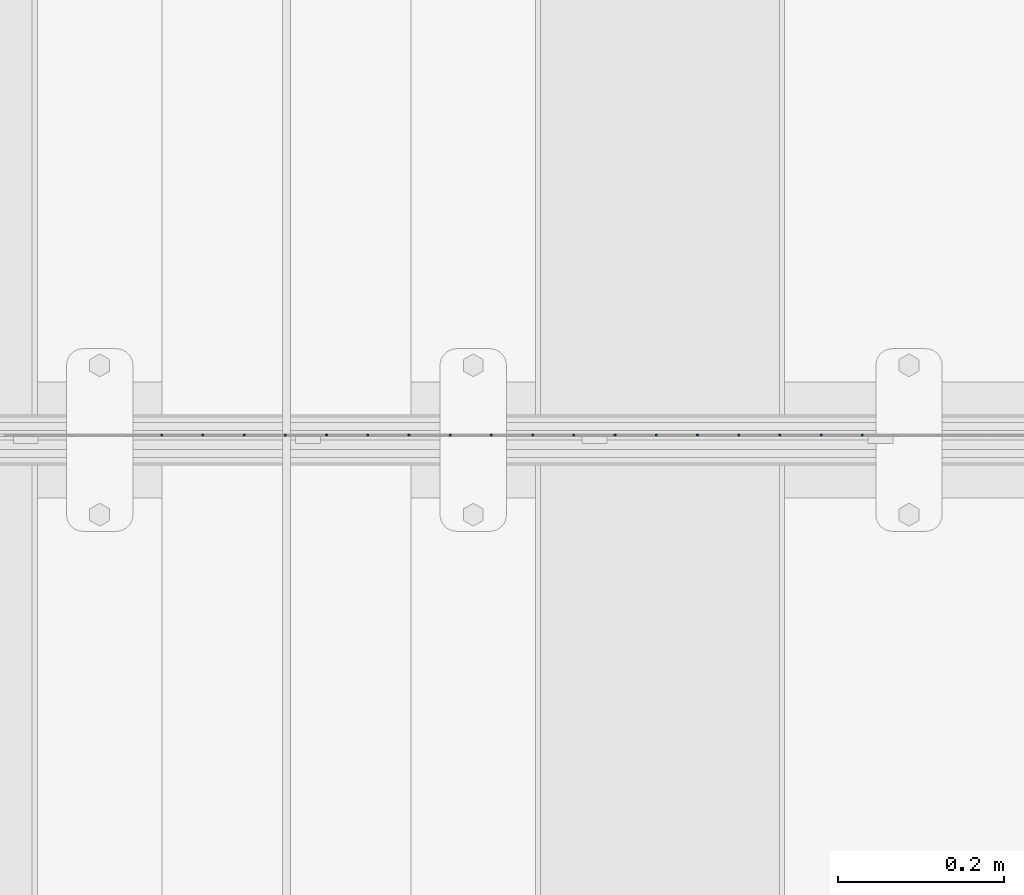
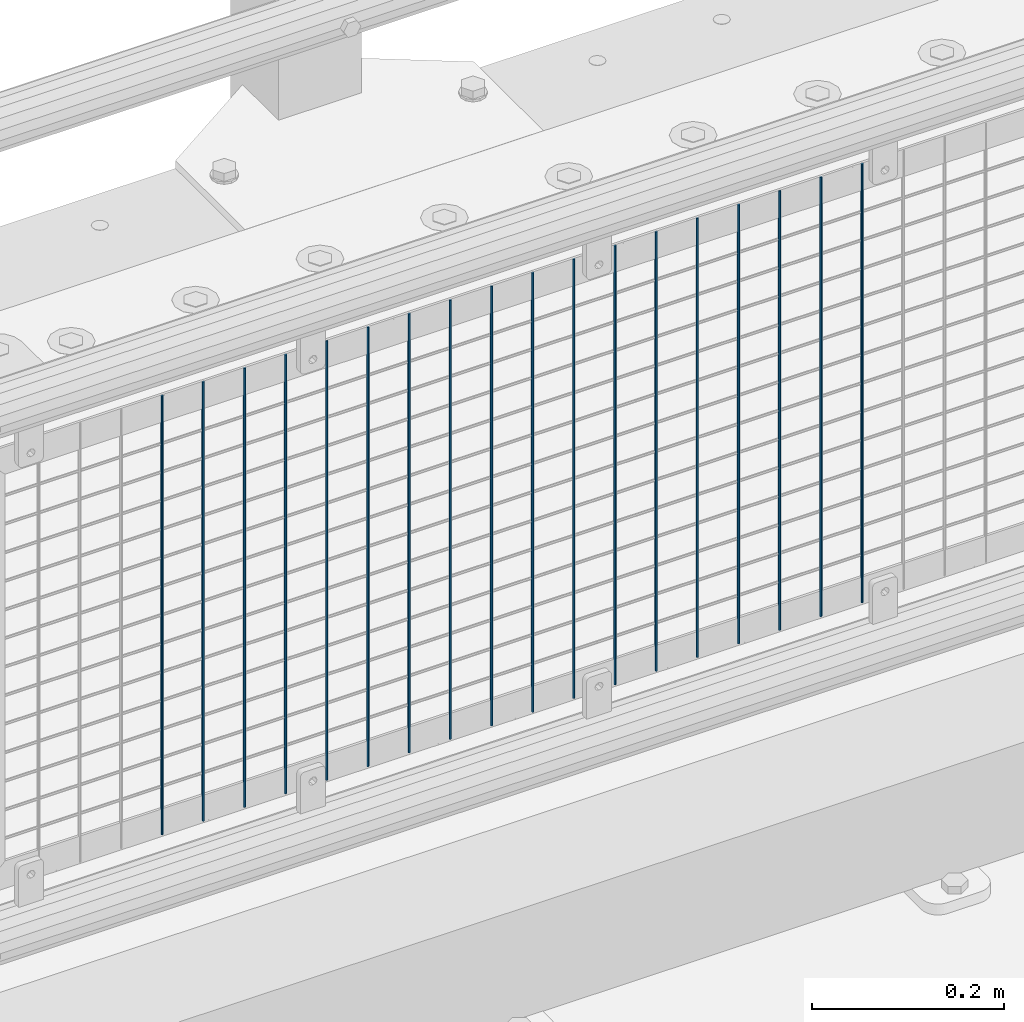
# One storey, part 79 of 208: 18 columns.
"""IFC2X3 building model written with IfcOpenShell, lengths in millimetres."""

from ifc_helpers import new_model, si_unit, frame, origin_with_axes, place, context, subcontext, project, spatial, faceted_brep, material, type_object, element, save


model = new_model("IFC2X3")

# Units and contexts
model_context = context("Model", 3, precision=1e-05, world=origin_with_axes())
body_context = subcontext(model_context, "Body", "Model", "MODEL_VIEW")
ifc_project = project(units=[si_unit("LENGTHUNIT", "METRE", prefix="MILLI"), si_unit("AREAUNIT", "SQUARE_METRE"), si_unit("VOLUMEUNIT", "CUBIC_METRE"), si_unit("MASSUNIT", "GRAM", prefix="KILO"), si_unit("TIMEUNIT", "SECOND"), si_unit("PLANEANGLEUNIT", "RADIAN"), si_unit("SOLIDANGLEUNIT", "STERADIAN"), si_unit("THERMODYNAMICTEMPERATUREUNIT", "DEGREE_CELSIUS"), si_unit("LUMINOUSINTENSITYUNIT", "LUMEN")], contexts=[model_context])

# Site, building, storey
site_placement = place(None, origin_with_axes())
site = spatial("IfcSite", under=ifc_project, at=site_placement, CompositionType="ELEMENT")
building_placement = place(site_placement, origin_with_axes())
building = spatial("IfcBuilding", under=site, at=building_placement, Name="Standard", CompositionType="ELEMENT")
storey_placement = place(building_placement, origin_with_axes())
storey = spatial("IfcBuildingStorey", under=building, at=storey_placement, Name="Undefined", CompositionType="ELEMENT", Elevation=0.0)

# Columns
ifc_material = material(Name="Misc_Undefined")
column_type = type_object("IfcColumnType", Name="D3", PredefinedType="NOTDEFINED")
for number, where, z_axis, x_axis in (
    (1, (-29506.245, 4670.50000000001, 353.020000000005), (-1.0, 0.0, 0.0), (0.0, 0.0, 1.0)),
    (2, (-29555.9, 4670.50000000001, 353.020000000005), (-1.0, 0.0, 0.0), (0.0, 0.0, 1.0)),
    (3, (-29605.555, 4670.50000000001, 353.020000000005), (-1.0, 0.0, 0.0), (0.0, 0.0, 1.0)),
    (4, (-29655.21, 4670.50000000001, 353.020000000005), (-1.0, 0.0, 0.0), (0.0, 0.0, 1.0)),
    (5, (-29704.865, 4670.50000000001, 353.020000000005), (-1.0, 0.0, 0.0), (0.0, 0.0, 1.0)),
    (6, (-29754.52, 4670.50000000001, 353.020000000005), (-1.0, 0.0, 0.0), (0.0, 0.0, 1.0)),
    (7, (-29804.175, 4670.50000000001, 353.020000000005), (-1.0, 0.0, 0.0), (0.0, 0.0, 1.0)),
    (8, (-29853.83, 4670.50000000001, 353.020000000005), (-1.0, 0.0, 0.0), (0.0, 0.0, 1.0)),
    (9, (-29903.485, 4670.50000000001, 353.020000000005), (-1.0, 0.0, 0.0), (0.0, 0.0, 1.0)),
    (10, (-29953.14, 4670.50000000001, 353.020000000005), (-1.0, 0.0, 0.0), (0.0, 0.0, 1.0)),
    (11, (-30002.795, 4670.50000000001, 353.020000000005), (-1.0, 0.0, 0.0), (0.0, 0.0, 1.0)),
    (12, (-30052.45, 4670.50000000001, 353.020000000005), (-1.0, 0.0, 0.0), (0.0, 0.0, 1.0)),
    (13, (-30102.105, 4670.50000000001, 353.020000000005), (-1.0, 0.0, 0.0), (0.0, 0.0, 1.0)),
    (14, (-30151.76, 4670.50000000001, 353.020000000005), (-1.0, 0.0, 0.0), (0.0, 0.0, 1.0)),
    (15, (-30201.415, 4670.50000000001, 353.020000000005), (-1.0, 0.0, 0.0), (0.0, 0.0, 1.0)),
    (16, (-30251.07, 4670.50000000001, 353.020000000005), (-1.0, 0.0, 0.0), (0.0, 0.0, 1.0)),
    (17, (-30300.725, 4670.50000000001, 353.020000000005), (-1.0, 0.0, 0.0), (0.0, 0.0, 1.0)),
    (18, (-30350.38, 4670.50000000001, 353.020000000005), (-1.0, 0.0, 0.0), (0.0, 0.0, 1.0)),
):
    element("IfcColumn", number, at=place(storey_placement, frame(where, z_axis=z_axis, x_axis=x_axis)), inside=storey, type_object=column_type, material=ifc_material, ObjectType="D3", context=body_context, shape_type="Brep", body=[
        faceted_brep([(0.0, -1.49999999999909, 3.63797880709171e-12), (-7.27595761418343e-12, -0.749999999999091, -1.29903810567669), (560.0, -0.75, -1.29903810567703), (560.0, -1.5, 0.0), (-3.63797880709171e-12, 0.750000000000909, -1.29903810567669), (560.0, 0.75, -1.29903810567703), (0.0, 1.50000000000182, 3.63797880709171e-12), (560.0, 1.5, 0.0), (-3.63797880709171e-12, 0.750000000000909, 1.29903810567669), (560.0, 0.75, 1.29903810567703), (-7.27595761418343e-12, -0.749999999999091, 1.29903810567669), (560.0, -0.75, 1.29903810567703)], [[[0, 1, 2, 3]], [[1, 4, 5, 2]], [[4, 6, 7, 5]], [[6, 8, 9, 7]], [[8, 10, 11, 9]], [[10, 0, 3, 11]], [[5, 7, 9, 11, 3, 2]], [[10, 8, 6, 4, 1, 0]]]),
    ])

save(model, "model.ifc")
